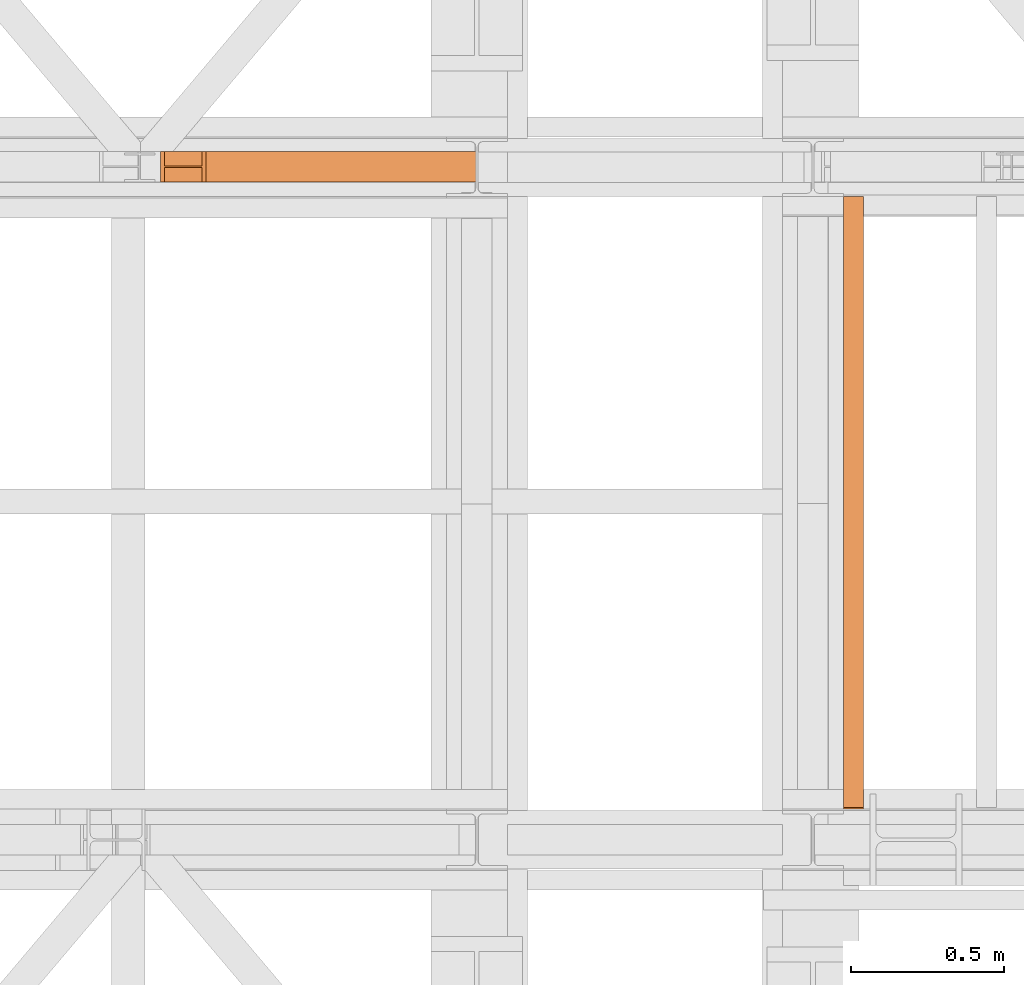
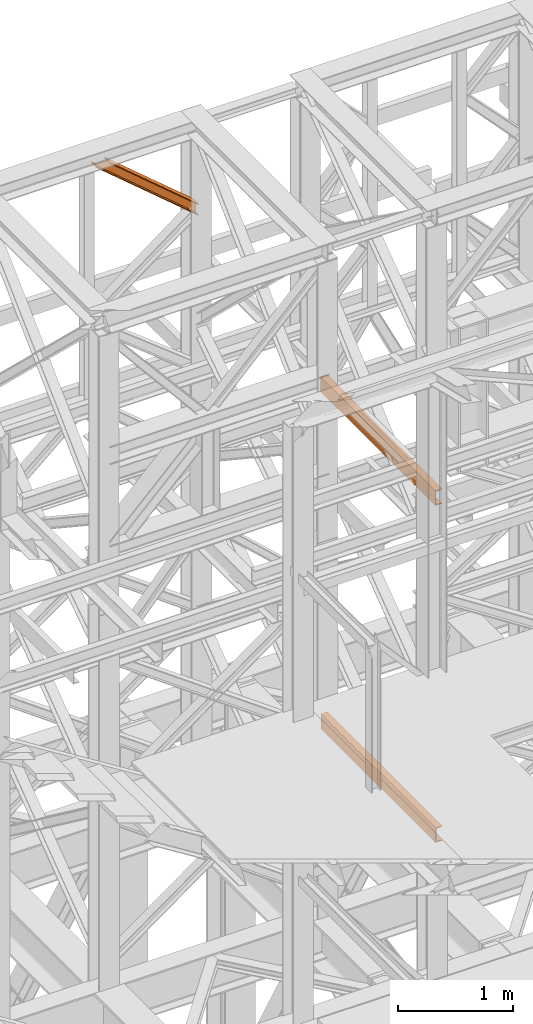
# One storey, part 127 of 208: 3 proxies.
"""IFC2X3 building model written with IfcOpenShell, lengths in millimetres."""

from ifc_helpers import new_model, entity, si_unit, converted_unit, frame, origin, origin_with_axes, place, context, subcontext, project, spatial, faceted_brep, element, save


model = new_model("IFC2X3")

# Units and contexts
model_context = context("Model", 3, precision=1e-05, world=origin())
plan_context = context("Plan", 3, precision=1e-05, world=origin())
body_context = subcontext(model_context, "Body", "Model", "MODEL_VIEW")
ifc_project = project(units=[si_unit("LENGTHUNIT", "METRE", prefix="MILLI"), converted_unit("PLANEANGLEUNIT", "DEGREE", entity("IfcPlaneAngleMeasure", 0.0174532925199433), si_unit("PLANEANGLEUNIT", "RADIAN"), dimensions=[0, 0, 0, 0, 0, 0, 0]), si_unit("AREAUNIT", "SQUARE_METRE"), si_unit("VOLUMEUNIT", "CUBIC_METRE")], contexts=[model_context, plan_context])

# Building, storey
building_placement = place(None, origin())
building = spatial("IfcBuilding", under=ifc_project, at=building_placement, CompositionType="COMPLEX")
storey_placement = place(building_placement, origin_with_axes())
storey = spatial("IfcBuildingStorey", under=building, at=storey_placement, Name="Geschoss", CompositionType="ELEMENT")

# Proxies
proxy_1_placement = place(storey_placement, frame((1158.407519562538, -13810.57439404318, 11377.26806390157), z_axis=(0.0, 0.0, 1.0), x_axis=(1.0, 0.0, 0.0)))
element("IfcBuildingElementProxy", 1, at=proxy_1_placement, inside=storey, context=body_context, shape_type="Brep", body=[
    faceted_brep([(1031.899031272101, 0.00999999999839929, 114.8626373950665), (135.8094612807452, 0.01000000000021828, 872.7319947922351), (148.1548668517232, 0.01000000000021828, 872.7319947922351), (1031.899031272102, 0.00999999999839929, 125.3037862491656), (1031.899031272102, 0.00999999999839929, 125.3037862491656), (148.1548668517232, 0.01000000000021828, 872.7319947922351), (148.1548668517241, 100.0100000000002, 872.7319947922351), (1031.899031272101, 100.0099999999984, 125.3037862491656), (1031.899031272101, 100.0099999999984, 125.3037862491656), (148.1548668517241, 100.0100000000002, 872.7319947922351), (135.8094612807442, 100.0100000000002, 872.7319947922351), (1031.899031272101, 100.0099999999984, 114.8626373950665), (1031.899031272101, 100.0099999999984, 114.8626373950665), (135.8094612807442, 100.0100000000002, 872.7319947922351), (135.809461280747, 52.51000000000022, 872.7319947922351), (1031.8990312721, 52.5099999999984, 114.8626373950683), (1031.8990312721, 52.5099999999984, 114.8626373950683), (135.809461280747, 52.51000000000022, 872.7319947922351), (12.35540557097716, 52.51000000000022, 872.7319947922351), (1031.899031272101, 52.5099999999984, 10.45114885409566), (1031.899031272101, 52.5099999999984, 10.45114885409566), (12.35540557097716, 52.51000000000022, 872.7319947922351), (12.35540557097716, 100.0100000000002, 872.7319947922333), (1031.8990312721, 100.0099999999984, 10.45114885409566), (1031.8990312721, 100.0099999999984, 10.45114885409566), (12.35540557097716, 100.0100000000002, 872.7319947922333), (0.01000000000180989, 100.0100000000002, 872.7319947922351), (1031.899031272101, 100.0099999999984, 0.01000000000021828), (1031.899031272101, 100.0099999999984, 0.01000000000021828), (0.01000000000180989, 100.0100000000002, 872.7319947922351), (0.009999999999990905, 0.01000000000021828, 872.7319947922351), (1031.899031272101, 0.00999999999839929, 0.01000000000021828), (1031.899031272101, 0.00999999999839929, 0.01000000000021828), (0.009999999999990905, 0.01000000000021828, 872.7319947922351), (12.35540557097716, 0.01000000000021828, 872.7319947922351), (1031.899031272101, 0.00999999999839929, 10.45114885409566), (1031.899031272101, 0.00999999999839929, 10.45114885409566), (12.35540557097716, 0.01000000000021828, 872.7319947922351), (12.35540557097716, 47.51000000000022, 872.7319947922333), (1031.899031272101, 47.5099999999984, 10.45114885409566), (1031.899031272101, 47.5099999999984, 10.45114885409566), (12.35540557097716, 47.51000000000022, 872.7319947922333), (135.8094612807452, 47.51000000000022, 872.7319947922351), (1031.899031272101, 47.5099999999984, 114.8626373950665), (1031.899031272101, 47.5099999999984, 114.8626373950665), (135.8094612807452, 47.51000000000022, 872.7319947922351), (135.8094612807452, 0.01000000000021828, 872.7319947922351), (1031.899031272101, 0.00999999999839929, 114.8626373950665), (135.8094612807452, 0.01000000000021828, 872.7319947922351), (135.8094612807452, 47.51000000000022, 872.7319947922351), (12.35540557097716, 47.51000000000022, 872.7319947922333), (12.35540557097716, 0.01000000000021828, 872.7319947922351), (0.009999999999990905, 0.01000000000021828, 872.7319947922351), (0.01000000000180989, 100.0100000000002, 872.7319947922351), (12.35540557097716, 100.0100000000002, 872.7319947922333), (12.35540557097716, 52.51000000000022, 872.7319947922351), (135.809461280747, 52.51000000000022, 872.7319947922351), (135.8094612807442, 100.0100000000002, 872.7319947922351), (148.1548668517241, 100.0100000000002, 872.7319947922351), (148.1548668517232, 0.01000000000021828, 872.7319947922351), (1031.899031272102, 0.00999999999839929, 125.3037862491656), (1031.899031272101, 100.0099999999984, 125.3037862491656), (1031.899031272101, 100.0099999999984, 114.8626373950665), (1031.8990312721, 52.5099999999984, 114.8626373950683), (1031.899031272101, 52.5099999999984, 10.45114885409566), (1031.8990312721, 100.0099999999984, 10.45114885409566), (1031.899031272101, 100.0099999999984, 0.01000000000021828), (1031.899031272101, 0.00999999999839929, 0.01000000000021828), (1031.899031272101, 0.00999999999839929, 10.45114885409566), (1031.899031272101, 47.5099999999984, 10.45114885409566), (1031.899031272101, 47.5099999999984, 114.8626373950665), (1031.899031272101, 0.00999999999839929, 114.8626373950665)], [[[0, 1, 2, 3]], [[4, 5, 6, 7]], [[8, 9, 10, 11]], [[12, 13, 14, 15]], [[16, 17, 18, 19]], [[20, 21, 22, 23]], [[24, 25, 26, 27]], [[28, 29, 30, 31]], [[32, 33, 34, 35]], [[36, 37, 38, 39]], [[40, 41, 42, 43]], [[44, 45, 46, 47]], [[48, 49, 50, 51, 52, 53, 54, 55, 56, 57, 58, 59]], [[60, 61, 62, 63, 64, 65, 66, 67, 68, 69, 70, 71]]], orient=[[False], [False], [False], [False], [False], [False], [False], [False], [False], [False], [False], [False], [False], [False]]),
])
proxy_2_placement = place(storey_placement, frame((3393.254970018781, -15857.57439274273, 9109.989999999998), z_axis=(0.0, 0.0, 1.0), x_axis=(1.0, 0.0, 0.0)))
element("IfcBuildingElementProxy", 2, at=proxy_2_placement, inside=storey, context=body_context, shape_type="Brep", body=[
    faceted_brep([(0.01000000000203727, 2000.009997019768, 160.0100000000002), (65.01000000000249, 2000.009997019768, 160.0100000000002), (65.01000000000022, 0.01000000000021828, 160.0100000000002), (0.01000000000021828, 0.01000000000021828, 160.0100000000002), (65.01000000000249, 2000.009997019768, 160.0100000000002), (65.01000000000249, 2000.009997019768, 156.8875719297539), (65.01000000000022, 0.01000000000021828, 156.8875719297539), (65.01000000000022, 0.01000000000021828, 160.0100000000002), (65.01000000000249, 2000.009997019768, 156.8875719297539), (64.76726342282973, 2000.009997019768, 155.2717110918293), (64.76726342282745, 0.01000000000021828, 155.2717110918293), (65.01000000000022, 0.01000000000021828, 156.8875719297539), (64.76726342282973, 2000.009997019768, 155.2717110918293), (64.06053228585779, 2000.009997019768, 153.7984655565542), (64.06053228585915, 0.01000000000021828, 153.7984655565542), (64.76726342282745, 0.01000000000021828, 155.2717110918293), (64.06053228585779, 2000.009997019768, 153.7984655565542), (62.9521516384707, 2000.009997019768, 152.5978732961266), (62.95215163846842, 0.01000000000021828, 152.5978732961266), (64.06053228585915, 0.01000000000021828, 153.7984655565542), (62.9521516384707, 2000.009997019768, 152.5978732961266), (61.53995641148549, 2000.009997019768, 151.7759086082897), (61.53995641148322, 0.01000000000021828, 151.7759086082897), (62.95215163846842, 0.01000000000021828, 152.5978732961266), (61.53995641148549, 2000.009997019768, 151.7759086082897), (59.94859872255665, 2000.009997019768, 151.4050878978051), (59.94859872255438, 0.01000000000021828, 151.4050878978051), (61.53995641148322, 0.01000000000021828, 151.7759086082897), (59.94859872255665, 2000.009997019768, 151.4050878978051), (17.1726751660317, 2000.009997019768, 147.9830140132835), (17.17267516602988, 0.01000000000021828, 147.9830140132835), (59.94859872255438, 0.01000000000021828, 151.4050878978051), (17.1726751660317, 2000.009997019768, 147.9830140132835), (14.20840820801095, 2000.009997019768, 147.318026761528), (14.20840820800913, 0.01000000000021828, 147.318026761528), (17.17267516602988, 0.01000000000021828, 147.9830140132835), (14.20840820801095, 2000.009997019768, 147.318026761528), (11.43861959928836, 2000.009997019768, 145.7058782528511), (11.43861959929018, 0.01000000000021828, 145.7058782528511), (14.20840820800913, 0.01000000000021828, 147.318026761528), (11.43861959928836, 2000.009997019768, 145.7058782528511), (9.3226201815487, 2000.009997019768, 143.4138384829421), (9.322620181546881, 0.01000000000021828, 143.4138384829421), (11.43861959929018, 0.01000000000021828, 145.7058782528511), (9.3226201815487, 2000.009997019768, 143.4138384829421), (7.973406192788389, 2000.009997019768, 140.6012788246917), (7.97340619278657, 0.01000000000021828, 140.6012788246917), (9.322620181546881, 0.01000000000021828, 143.4138384829421), (7.973406192788389, 2000.009997019768, 140.6012788246917), (7.510000000002037, 2000.009997019768, 137.5164535886543), (7.510000000000218, 0.01000000000021828, 137.5164535886543), (7.97340619278657, 0.01000000000021828, 140.6012788246917), (7.510000000002037, 2000.009997019768, 137.5164535886543), (7.510000000002037, 2000.009997019768, 22.503546411348), (7.510000000000218, 0.01000000000021828, 22.503546411348), (7.510000000000218, 0.01000000000021828, 137.5164535886543), (7.510000000002037, 2000.009997019768, 22.503546411348), (7.973406192788389, 2000.009997019768, 19.41872117530875), (7.97340619278657, 0.01000000000021828, 19.41872117530875), (7.510000000000218, 0.01000000000021828, 22.503546411348), (7.973406192788389, 2000.009997019768, 19.41872117530875), (9.3226201815487, 2000.009997019768, 16.60616151705835), (9.322620181546881, 0.01000000000021828, 16.60616151705835), (7.97340619278657, 0.01000000000021828, 19.41872117530875), (9.3226201815487, 2000.009997019768, 16.60616151705835), (11.43861959928836, 2000.009997019768, 14.31412174714933), (11.43861959929018, 0.01000000000021828, 14.31412174714933), (9.322620181546881, 0.01000000000021828, 16.60616151705835), (11.43861959928836, 2000.009997019768, 14.31412174714933), (14.13462866898408, 2000.009997019768, 12.74491643400688), (14.1346286689859, 0.01000000000021828, 12.74491643400688), (11.43861959929018, 0.01000000000021828, 14.31412174714933), (14.13462866898408, 2000.009997019768, 12.74491643400688), (17.1726751660317, 2000.009997019768, 12.03698598671872), (17.17267516602988, 0.01000000000021828, 12.03698598671872), (14.1346286689859, 0.01000000000021828, 12.74491643400688), (17.1726751660317, 2000.009997019768, 12.03698598671872), (59.94859872255665, 2000.009997019768, 8.614912102195376), (59.94859872255438, 0.01000000000021828, 8.614912102195376), (17.17267516602988, 0.01000000000021828, 12.03698598671872), (59.94859872255665, 2000.009997019768, 8.614912102195376), (61.53995641148549, 2000.009997019768, 8.244091391710754), (61.53995641148322, 0.01000000000021828, 8.244091391710754), (59.94859872255438, 0.01000000000021828, 8.614912102195376), (61.53995641148549, 2000.009997019768, 8.244091391710754), (62.9521516384707, 2000.009997019768, 7.422126703873801), (62.95215163846842, 0.01000000000021828, 7.422126703873801), (61.53995641148322, 0.01000000000021828, 8.244091391710754), (62.9521516384707, 2000.009997019768, 7.422126703873801), (64.06053228585779, 2000.009997019768, 6.221534443446217), (64.06053228585915, 0.01000000000021828, 6.221534443446217), (62.95215163846842, 0.01000000000021828, 7.422126703873801), (64.06053228585779, 2000.009997019768, 6.221534443446217), (64.76726342282973, 2000.009997019768, 4.748288908172981), (64.76726342282745, 0.01000000000021828, 4.748288908172981), (64.06053228585915, 0.01000000000021828, 6.221534443446217), (64.76726342282973, 2000.009997019768, 4.748288908172981), (65.01000000000249, 2000.009997019768, 0.01000000000021828), (65.01000000000022, 0.01000000000021828, 0.01000000000021828), (64.76726342282745, 0.01000000000021828, 4.748288908172981), (65.01000000000249, 2000.009997019768, 0.01000000000021828), (0.01000000000203727, 2000.009997019768, 0.01000000000021828), (0.01000000000021828, 0.01000000000021828, 0.01000000000021828), (65.01000000000022, 0.01000000000021828, 0.01000000000021828), (0.01000000000203727, 2000.009997019768, 0.01000000000021828), (0.01000000000203727, 2000.009997019768, 160.0100000000002), (0.01000000000021828, 0.01000000000021828, 160.0100000000002), (0.01000000000021828, 0.01000000000021828, 0.01000000000021828), (0.01000000000203727, 2000.009997019768, 160.0100000000002), (0.01000000000203727, 2000.009997019768, 0.01000000000021828), (65.01000000000249, 2000.009997019768, 0.01000000000021828), (64.76726342282973, 2000.009997019768, 4.748288908172981), (64.06053228585779, 2000.009997019768, 6.221534443446217), (62.9521516384707, 2000.009997019768, 7.422126703873801), (61.53995641148549, 2000.009997019768, 8.244091391710754), (59.94859872255665, 2000.009997019768, 8.614912102195376), (17.1726751660317, 2000.009997019768, 12.03698598671872), (14.13462866898408, 2000.009997019768, 12.74491643400688), (11.43861959928836, 2000.009997019768, 14.31412174714933), (9.3226201815487, 2000.009997019768, 16.60616151705835), (7.973406192788389, 2000.009997019768, 19.41872117530875), (7.510000000002037, 2000.009997019768, 22.503546411348), (7.510000000002037, 2000.009997019768, 137.5164535886543), (7.973406192788389, 2000.009997019768, 140.6012788246917), (9.3226201815487, 2000.009997019768, 143.4138384829421), (11.43861959928836, 2000.009997019768, 145.7058782528511), (14.20840820801095, 2000.009997019768, 147.318026761528), (17.1726751660317, 2000.009997019768, 147.9830140132835), (59.94859872255665, 2000.009997019768, 151.4050878978051), (61.53995641148549, 2000.009997019768, 151.7759086082897), (62.9521516384707, 2000.009997019768, 152.5978732961266), (64.06053228585779, 2000.009997019768, 153.7984655565542), (64.76726342282973, 2000.009997019768, 155.2717110918293), (65.01000000000249, 2000.009997019768, 156.8875719297539), (65.01000000000249, 2000.009997019768, 160.0100000000002), (0.01000000000021828, 0.01000000000021828, 160.0100000000002), (65.01000000000022, 0.01000000000021828, 160.0100000000002), (65.01000000000022, 0.01000000000021828, 156.8875719297539), (64.76726342282745, 0.01000000000021828, 155.2717110918293), (64.06053228585915, 0.01000000000021828, 153.7984655565542), (62.95215163846842, 0.01000000000021828, 152.5978732961266), (61.53995641148322, 0.01000000000021828, 151.7759086082897), (59.94859872255438, 0.01000000000021828, 151.4050878978051), (17.17267516602988, 0.01000000000021828, 147.9830140132835), (14.20840820800913, 0.01000000000021828, 147.318026761528), (11.43861959929018, 0.01000000000021828, 145.7058782528511), (9.322620181546881, 0.01000000000021828, 143.4138384829421), (7.97340619278657, 0.01000000000021828, 140.6012788246917), (7.510000000000218, 0.01000000000021828, 137.5164535886543), (7.510000000000218, 0.01000000000021828, 22.503546411348), (7.97340619278657, 0.01000000000021828, 19.41872117530875), (9.322620181546881, 0.01000000000021828, 16.60616151705835), (11.43861959929018, 0.01000000000021828, 14.31412174714933), (14.1346286689859, 0.01000000000021828, 12.74491643400688), (17.17267516602988, 0.01000000000021828, 12.03698598671872), (59.94859872255438, 0.01000000000021828, 8.614912102195376), (61.53995641148322, 0.01000000000021828, 8.244091391710754), (62.95215163846842, 0.01000000000021828, 7.422126703873801), (64.06053228585915, 0.01000000000021828, 6.221534443446217), (64.76726342282745, 0.01000000000021828, 4.748288908172981), (65.01000000000022, 0.01000000000021828, 0.01000000000021828), (0.01000000000021828, 0.01000000000021828, 0.01000000000021828)], [[[0, 1, 2, 3]], [[4, 5, 6, 7]], [[8, 9, 10, 11]], [[12, 13, 14, 15]], [[16, 17, 18, 19]], [[20, 21, 22, 23]], [[24, 25, 26, 27]], [[28, 29, 30, 31]], [[32, 33, 34, 35]], [[36, 37, 38, 39]], [[40, 41, 42, 43]], [[44, 45, 46, 47]], [[48, 49, 50, 51]], [[52, 53, 54, 55]], [[56, 57, 58, 59]], [[60, 61, 62, 63]], [[64, 65, 66, 67]], [[68, 69, 70, 71]], [[72, 73, 74, 75]], [[76, 77, 78, 79]], [[80, 81, 82, 83]], [[84, 85, 86, 87]], [[88, 89, 90, 91]], [[92, 93, 94, 95]], [[96, 97, 98, 99]], [[100, 101, 102, 103]], [[104, 105, 106, 107]], [[108, 109, 110, 111, 112, 113, 114, 115, 116, 117, 118, 119, 120, 121, 122, 123, 124, 125, 126, 127, 128, 129, 130, 131, 132, 133, 134]], [[135, 136, 137, 138, 139, 140, 141, 142, 143, 144, 145, 146, 147, 148, 149, 150, 151, 152, 153, 154, 155, 156, 157, 158, 159, 160, 161]]], orient=[[False], [False], [False], [False], [False], [False], [False], [False], [False], [False], [False], [False], [False], [False], [False], [False], [False], [False], [False], [False], [False], [False], [False], [False], [False], [False], [False], [False], [False]]),
])
proxy_3_placement = place(storey_placement, frame((3393.254970018782, -15862.56585521703, 5524.960005364417), z_axis=(0.0, 0.0, 1.0), x_axis=(1.0, 0.0, 0.0)))
element("IfcBuildingElementProxy", 3, at=proxy_3_placement, inside=storey, context=body_context, shape_type="Brep", body=[
    faceted_brep([(0.01000000000203727, 2000.009997019768, 160.0100000000002), (65.01000000000204, 2000.009997019768, 160.0100000000002), (65.00999999999976, 0.01000000000021828, 160.0100000000002), (0.009999999999763531, 0.01000000000021828, 160.0100000000002), (65.01000000000204, 2000.009997019768, 160.0100000000002), (65.01000000000204, 2000.009997019768, 156.8875719297539), (65.00999999999976, 0.01000000000021828, 156.8875719297539), (65.00999999999976, 0.01000000000021828, 160.0100000000002), (65.01000000000204, 2000.009997019768, 156.8875719297539), (64.76726342282927, 2000.009997019768, 155.2717110918293), (64.767263422827, 0.01000000000021828, 155.2717110918293), (65.00999999999976, 0.01000000000021828, 156.8875719297539), (64.76726342282927, 2000.009997019768, 155.2717110918293), (64.06053228585733, 2000.009997019768, 153.7984655565542), (64.0605322858587, 0.01000000000021828, 153.7984655565542), (64.767263422827, 0.01000000000021828, 155.2717110918293), (64.06053228585733, 2000.009997019768, 153.7984655565542), (62.95215163847024, 2000.009997019768, 152.5978732961266), (62.95215163846797, 0.01000000000021828, 152.5978732961266), (64.0605322858587, 0.01000000000021828, 153.7984655565542), (62.95215163847024, 2000.009997019768, 152.5978732961266), (61.53995641148504, 2000.009997019768, 151.7759086082897), (61.53995641148276, 0.01000000000021828, 151.7759086082897), (62.95215163846797, 0.01000000000021828, 152.5978732961266), (61.53995641148504, 2000.009997019768, 151.7759086082897), (59.9485987225562, 2000.009997019768, 151.4050878978051), (59.94859872255393, 0.01000000000021828, 151.4050878978051), (61.53995641148276, 0.01000000000021828, 151.7759086082897), (59.9485987225562, 2000.009997019768, 151.4050878978051), (17.1726751660317, 2000.009997019768, 147.9830140132835), (17.17267516602942, 0.01000000000021828, 147.9830140132835), (59.94859872255393, 0.01000000000021828, 151.4050878978051), (17.1726751660317, 2000.009997019768, 147.9830140132835), (14.20840820801095, 2000.009997019768, 147.318026761528), (14.20840820800868, 0.01000000000021828, 147.318026761528), (17.17267516602942, 0.01000000000021828, 147.9830140132835), (14.20840820801095, 2000.009997019768, 147.318026761528), (11.43861959928836, 2000.009997019768, 145.7058782528511), (11.43861959928972, 0.01000000000021828, 145.7058782528511), (14.20840820800868, 0.01000000000021828, 147.318026761528), (11.43861959928836, 2000.009997019768, 145.7058782528511), (9.3226201815487, 2000.009997019768, 143.4138384829421), (9.322620181546426, 0.01000000000021828, 143.4138384829421), (11.43861959928972, 0.01000000000021828, 145.7058782528511), (9.3226201815487, 2000.009997019768, 143.4138384829421), (7.973406192788389, 2000.009997019768, 140.6012788246917), (7.973406192786115, 0.01000000000021828, 140.6012788246917), (9.322620181546426, 0.01000000000021828, 143.4138384829421), (7.973406192788389, 2000.009997019768, 140.6012788246917), (7.510000000002037, 2000.009997019768, 137.5164535886543), (7.509999999999764, 0.01000000000021828, 137.5164535886543), (7.973406192786115, 0.01000000000021828, 140.6012788246917), (7.510000000002037, 2000.009997019768, 137.5164535886543), (7.510000000002037, 2000.009997019768, 22.503546411348), (7.509999999999764, 0.01000000000021828, 22.503546411348), (7.509999999999764, 0.01000000000021828, 137.5164535886543), (7.510000000002037, 2000.009997019768, 22.503546411348), (7.973406192788389, 2000.009997019768, 19.41872117530875), (7.973406192786115, 0.01000000000021828, 19.41872117530875), (7.509999999999764, 0.01000000000021828, 22.503546411348), (7.973406192788389, 2000.009997019768, 19.41872117530875), (9.3226201815487, 2000.009997019768, 16.60616151705835), (9.322620181546426, 0.01000000000021828, 16.60616151705835), (7.973406192786115, 0.01000000000021828, 19.41872117530875), (9.3226201815487, 2000.009997019768, 16.60616151705835), (11.43861959928836, 2000.009997019768, 14.31412174714933), (11.43861959928972, 0.01000000000021828, 14.31412174714933), (9.322620181546426, 0.01000000000021828, 16.60616151705835), (11.43861959928836, 2000.009997019768, 14.31412174714933), (14.13462866898408, 2000.009997019768, 12.74491643400688), (14.13462866898544, 0.01000000000021828, 12.74491643400688), (11.43861959928972, 0.01000000000021828, 14.31412174714933), (14.13462866898408, 2000.009997019768, 12.74491643400688), (17.1726751660317, 2000.009997019768, 12.03698598671872), (17.17267516602942, 0.01000000000021828, 12.03698598671872), (14.13462866898544, 0.01000000000021828, 12.74491643400688), (17.1726751660317, 2000.009997019768, 12.03698598671872), (59.9485987225562, 2000.009997019768, 8.614912102195376), (59.94859872255393, 0.01000000000021828, 8.614912102195376), (17.17267516602942, 0.01000000000021828, 12.03698598671872), (59.9485987225562, 2000.009997019768, 8.614912102195376), (61.53995641148504, 2000.009997019768, 8.244091391710754), (61.53995641148276, 0.01000000000021828, 8.244091391710754), (59.94859872255393, 0.01000000000021828, 8.614912102195376), (61.53995641148504, 2000.009997019768, 8.244091391710754), (62.95215163847024, 2000.009997019768, 7.422126703873801), (62.95215163846797, 0.01000000000021828, 7.422126703873801), (61.53995641148276, 0.01000000000021828, 8.244091391710754), (62.95215163847024, 2000.009997019768, 7.422126703873801), (64.06053228585733, 2000.009997019768, 6.221534443446217), (64.0605322858587, 0.01000000000021828, 6.221534443446217), (62.95215163846797, 0.01000000000021828, 7.422126703873801), (64.06053228585733, 2000.009997019768, 6.221534443446217), (64.76726342282927, 2000.009997019768, 4.748288908172981), (64.767263422827, 0.01000000000021828, 4.748288908172981), (64.0605322858587, 0.01000000000021828, 6.221534443446217), (64.76726342282927, 2000.009997019768, 4.748288908172981), (65.01000000000204, 2000.009997019768, 0.01000000000021828), (65.00999999999976, 0.01000000000021828, 0.01000000000021828), (64.767263422827, 0.01000000000021828, 4.748288908172981), (65.01000000000204, 2000.009997019768, 0.01000000000021828), (0.01000000000203727, 2000.009997019768, 0.01000000000021828), (0.009999999999763531, 0.01000000000021828, 0.01000000000021828), (65.00999999999976, 0.01000000000021828, 0.01000000000021828), (0.01000000000203727, 2000.009997019768, 0.01000000000021828), (0.01000000000203727, 2000.009997019768, 160.0100000000002), (0.009999999999763531, 0.01000000000021828, 160.0100000000002), (0.009999999999763531, 0.01000000000021828, 0.01000000000021828), (0.01000000000203727, 2000.009997019768, 160.0100000000002), (0.01000000000203727, 2000.009997019768, 0.01000000000021828), (65.01000000000204, 2000.009997019768, 0.01000000000021828), (64.76726342282927, 2000.009997019768, 4.748288908172981), (64.06053228585733, 2000.009997019768, 6.221534443446217), (62.95215163847024, 2000.009997019768, 7.422126703873801), (61.53995641148504, 2000.009997019768, 8.244091391710754), (59.9485987225562, 2000.009997019768, 8.614912102195376), (17.1726751660317, 2000.009997019768, 12.03698598671872), (14.13462866898408, 2000.009997019768, 12.74491643400688), (11.43861959928836, 2000.009997019768, 14.31412174714933), (9.3226201815487, 2000.009997019768, 16.60616151705835), (7.973406192788389, 2000.009997019768, 19.41872117530875), (7.510000000002037, 2000.009997019768, 22.503546411348), (7.510000000002037, 2000.009997019768, 137.5164535886543), (7.973406192788389, 2000.009997019768, 140.6012788246917), (9.3226201815487, 2000.009997019768, 143.4138384829421), (11.43861959928836, 2000.009997019768, 145.7058782528511), (14.20840820801095, 2000.009997019768, 147.318026761528), (17.1726751660317, 2000.009997019768, 147.9830140132835), (59.9485987225562, 2000.009997019768, 151.4050878978051), (61.53995641148504, 2000.009997019768, 151.7759086082897), (62.95215163847024, 2000.009997019768, 152.5978732961266), (64.06053228585733, 2000.009997019768, 153.7984655565542), (64.76726342282927, 2000.009997019768, 155.2717110918293), (65.01000000000204, 2000.009997019768, 156.8875719297539), (65.01000000000204, 2000.009997019768, 160.0100000000002), (0.009999999999763531, 0.01000000000021828, 160.0100000000002), (65.00999999999976, 0.01000000000021828, 160.0100000000002), (65.00999999999976, 0.01000000000021828, 156.8875719297539), (64.767263422827, 0.01000000000021828, 155.2717110918293), (64.0605322858587, 0.01000000000021828, 153.7984655565542), (62.95215163846797, 0.01000000000021828, 152.5978732961266), (61.53995641148276, 0.01000000000021828, 151.7759086082897), (59.94859872255393, 0.01000000000021828, 151.4050878978051), (17.17267516602942, 0.01000000000021828, 147.9830140132835), (14.20840820800868, 0.01000000000021828, 147.318026761528), (11.43861959928972, 0.01000000000021828, 145.7058782528511), (9.322620181546426, 0.01000000000021828, 143.4138384829421), (7.973406192786115, 0.01000000000021828, 140.6012788246917), (7.509999999999764, 0.01000000000021828, 137.5164535886543), (7.509999999999764, 0.01000000000021828, 22.503546411348), (7.973406192786115, 0.01000000000021828, 19.41872117530875), (9.322620181546426, 0.01000000000021828, 16.60616151705835), (11.43861959928972, 0.01000000000021828, 14.31412174714933), (14.13462866898544, 0.01000000000021828, 12.74491643400688), (17.17267516602942, 0.01000000000021828, 12.03698598671872), (59.94859872255393, 0.01000000000021828, 8.614912102195376), (61.53995641148276, 0.01000000000021828, 8.244091391710754), (62.95215163846797, 0.01000000000021828, 7.422126703873801), (64.0605322858587, 0.01000000000021828, 6.221534443446217), (64.767263422827, 0.01000000000021828, 4.748288908172981), (65.00999999999976, 0.01000000000021828, 0.01000000000021828), (0.009999999999763531, 0.01000000000021828, 0.01000000000021828)], [[[0, 1, 2, 3]], [[4, 5, 6, 7]], [[8, 9, 10, 11]], [[12, 13, 14, 15]], [[16, 17, 18, 19]], [[20, 21, 22, 23]], [[24, 25, 26, 27]], [[28, 29, 30, 31]], [[32, 33, 34, 35]], [[36, 37, 38, 39]], [[40, 41, 42, 43]], [[44, 45, 46, 47]], [[48, 49, 50, 51]], [[52, 53, 54, 55]], [[56, 57, 58, 59]], [[60, 61, 62, 63]], [[64, 65, 66, 67]], [[68, 69, 70, 71]], [[72, 73, 74, 75]], [[76, 77, 78, 79]], [[80, 81, 82, 83]], [[84, 85, 86, 87]], [[88, 89, 90, 91]], [[92, 93, 94, 95]], [[96, 97, 98, 99]], [[100, 101, 102, 103]], [[104, 105, 106, 107]], [[108, 109, 110, 111, 112, 113, 114, 115, 116, 117, 118, 119, 120, 121, 122, 123, 124, 125, 126, 127, 128, 129, 130, 131, 132, 133, 134]], [[135, 136, 137, 138, 139, 140, 141, 142, 143, 144, 145, 146, 147, 148, 149, 150, 151, 152, 153, 154, 155, 156, 157, 158, 159, 160, 161]]], orient=[[False], [False], [False], [False], [False], [False], [False], [False], [False], [False], [False], [False], [False], [False], [False], [False], [False], [False], [False], [False], [False], [False], [False], [False], [False], [False], [False], [False], [False]]),
])

save(model, "model.ifc")
